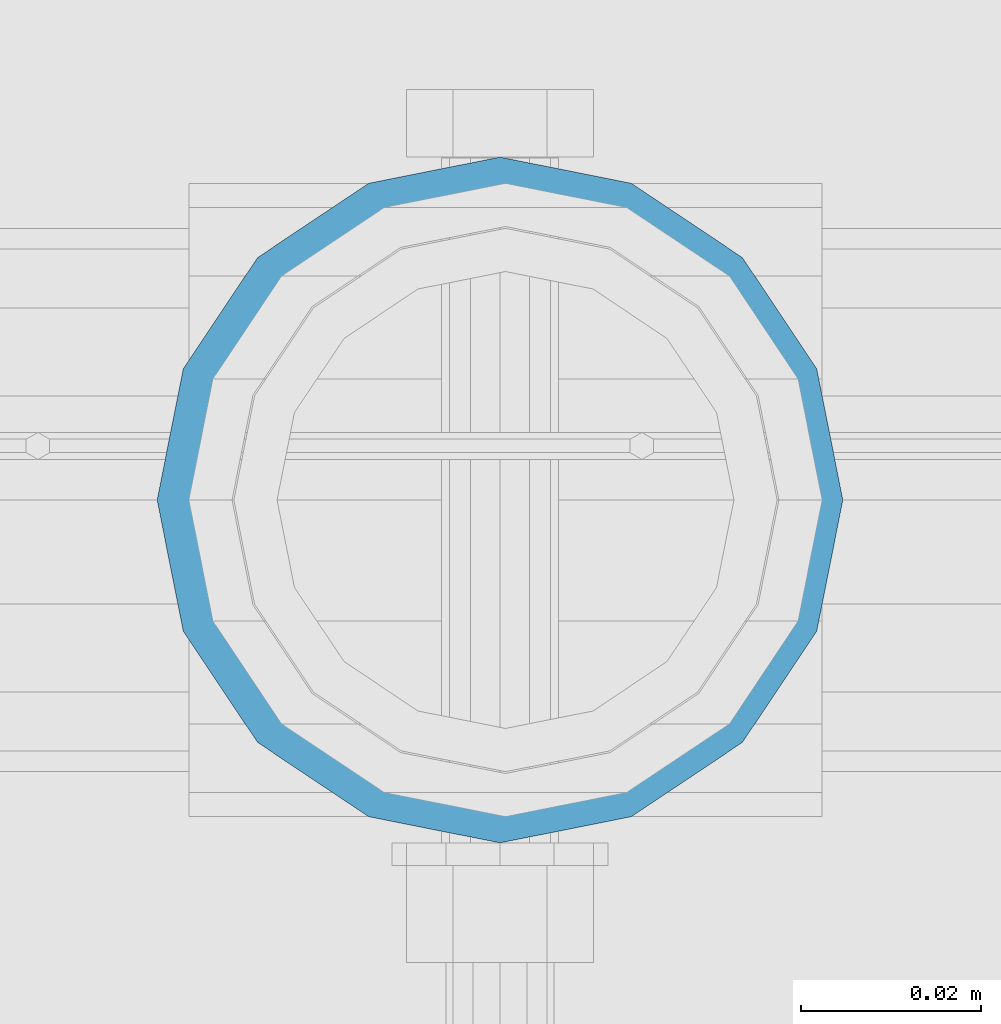
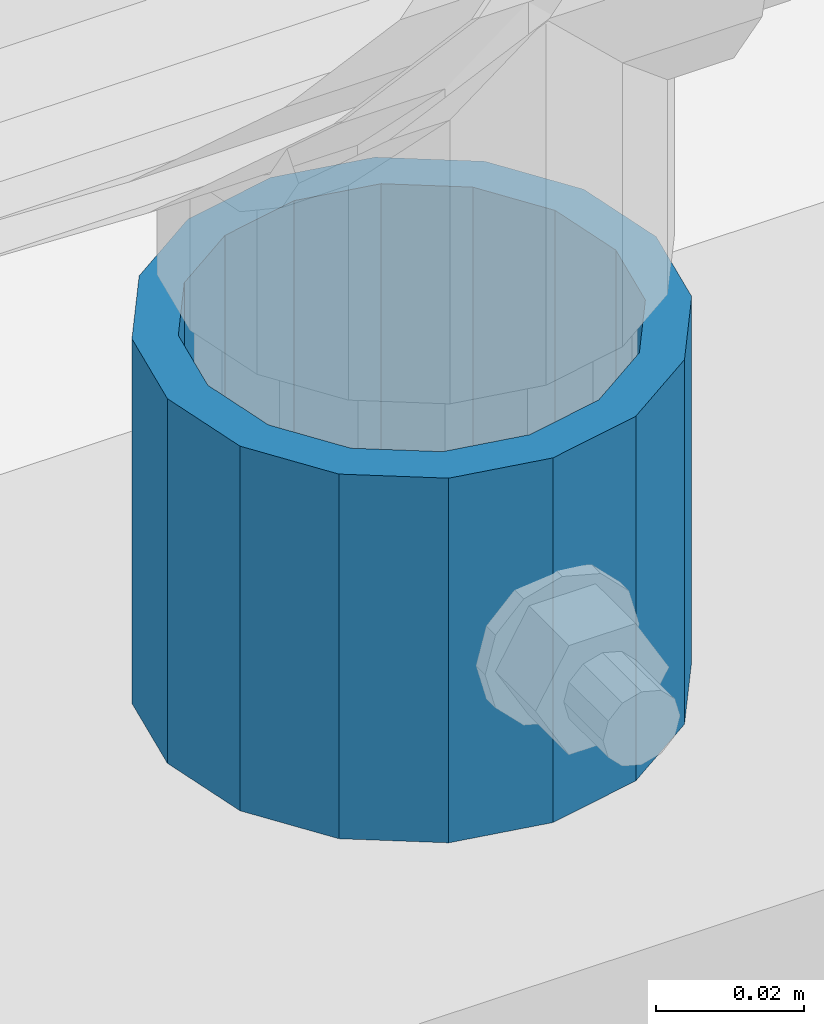
# One storey, part 96 of 240: 1 column.
"""IFC2X3 building model written with IfcOpenShell, lengths in millimetres."""

from ifc_helpers import new_model, si_unit, frame, origin_with_axes, place, context, subcontext, project, spatial, faceted_brep, material, type_object, element, save


model = new_model("IFC2X3")

# Units and contexts
model_context = context("Model", 3, precision=1e-05, world=origin_with_axes())
body_context = subcontext(model_context, "Body", "Model", "MODEL_VIEW")
ifc_project = project(units=[si_unit("LENGTHUNIT", "METRE", prefix="MILLI"), si_unit("AREAUNIT", "SQUARE_METRE"), si_unit("VOLUMEUNIT", "CUBIC_METRE"), si_unit("MASSUNIT", "GRAM", prefix="KILO"), si_unit("TIMEUNIT", "SECOND"), si_unit("PLANEANGLEUNIT", "RADIAN"), si_unit("SOLIDANGLEUNIT", "STERADIAN"), si_unit("THERMODYNAMICTEMPERATUREUNIT", "DEGREE_CELSIUS"), si_unit("LUMINOUSINTENSITYUNIT", "LUMEN")], contexts=[model_context])

# Site, building, storey
site_placement = place(None, origin_with_axes())
site = spatial("IfcSite", under=ifc_project, at=site_placement, CompositionType="ELEMENT")
building_placement = place(site_placement, origin_with_axes())
building = spatial("IfcBuilding", under=site, at=building_placement, Name="Standard", CompositionType="ELEMENT")
storey_placement = place(building_placement, origin_with_axes())
storey = spatial("IfcBuildingStorey", under=building, at=storey_placement, Name="Undefined", CompositionType="ELEMENT", Elevation=0.0)

# Column
ifc_material = material()
column_type = type_object("IfcColumnType", PredefinedType="NOTDEFINED")
column_placement = place(storey_placement, frame((55181.0, 34664.5, 168.019999999998), z_axis=(0.0, 1.0, 0.0), x_axis=(0.0, 0.0, 1.0)))
element("IfcColumn", 1, at=column_placement, inside=storey, type_object=column_type, material=ifc_material, context=body_context, shape_type="Brep", body=[
    faceted_brep([(0.0, -31.75, 0.0), (0.0, -29.3331751572332, 12.1501989775934), (60.0, -29.3331751572332, 12.1501989775934), (60.0, -31.75, 0.0), (0.0, -22.4506403026753, 22.4506403026753), (60.0, -22.4506403026753, 22.4506403026753), (0.0, -12.1501989775934, 29.3331751572332), (60.0, -12.1501989775934, 29.3331751572332), (0.0, 0.0, 31.75), (60.0, 0.0, 31.75), (0.0, 12.1501989775934, 29.3331751572332), (60.0, 12.1501989775934, 29.3331751572332), (0.0, 22.4506403026753, 22.4506403026753), (60.0, 22.4506403026753, 22.4506403026753), (0.0, 29.3331751572332, 12.1501989775934), (60.0, 29.3331751572332, 12.1501989775934), (0.0, 31.75, 0.0), (60.0, 31.75, 0.0), (0.0, 29.3331751572332, -12.1501989775934), (60.0, 29.3331751572332, -12.1501989775934), (0.0, 22.4506403026753, -22.4506403026753), (60.0, 22.4506403026753, -22.4506403026753), (0.0, 12.1501989775934, -29.3331751572332), (60.0, 12.1501989775934, -29.3331751572332), (0.0, 0.0, -31.75), (60.0, 0.0, -31.75), (0.0, -12.1501989775934, -29.3331751572332), (60.0, -12.1501989775934, -29.3331751572332), (0.0, -22.4506403026753, -22.4506403026753), (60.0, -22.4506403026753, -22.4506403026753), (0.0, -29.3331751572332, -12.1501989775934), (60.0, -29.3331751572332, -12.1501989775934), (0.0, -38.0500000000029, 0.0), (0.0, -35.1536162120537, -14.5611046014892), (60.0, -35.1536162120537, -14.5611046014892), (60.0, -38.0500000000029, 0.0), (0.0, -26.9054130241493, -26.9054130241493), (60.0, -26.9054130241493, -26.9054130241493), (0.0, -14.5611046014892, -35.1536162120537), (60.0, -14.5611046014892, -35.1536162120537), (0.0, 0.0, -38.0500000000029), (60.0, 0.0, -38.0500000000029), (0.0, 14.5611046014892, -35.1536162120537), (60.0, 14.5611046014892, -35.1536162120537), (0.0, 26.9054130241493, -26.9054130241493), (60.0, 26.9054130241493, -26.9054130241493), (0.0, 35.1536162120537, -14.5611046014892), (60.0, 35.1536162120537, -14.5611046014892), (0.0, 38.0500000000029, 0.0), (60.0, 38.0500000000029, 0.0), (0.0, 35.1536162120537, 14.5611046014892), (60.0, 35.1536162120537, 14.5611046014892), (0.0, 26.9054130241493, 26.9054130241493), (60.0, 26.9054130241493, 26.9054130241493), (0.0, 14.5611046014892, 35.1536162120537), (60.0, 14.5611046014892, 35.1536162120537), (0.0, 0.0, 38.0500000000029), (60.0, 0.0, 38.0500000000029), (0.0, -14.5611046014892, 35.1536162120537), (60.0, -14.5611046014892, 35.1536162120537), (0.0, -26.9054130241493, 26.9054130241493), (60.0, -26.9054130241493, 26.9054130241493), (0.0, -35.1536162120537, 14.5611046014892), (60.0, -35.1536162120537, 14.5611046014892)], [[[0, 1, 2, 3]], [[1, 4, 5, 2]], [[4, 6, 7, 5]], [[6, 8, 9, 7]], [[8, 10, 11, 9]], [[10, 12, 13, 11]], [[12, 14, 15, 13]], [[14, 16, 17, 15]], [[16, 18, 19, 17]], [[18, 20, 21, 19]], [[20, 22, 23, 21]], [[22, 24, 25, 23]], [[24, 26, 27, 25]], [[26, 28, 29, 27]], [[28, 30, 31, 29]], [[30, 0, 3, 31]], [[32, 33, 34, 35]], [[33, 36, 37, 34]], [[36, 38, 39, 37]], [[38, 40, 41, 39]], [[40, 42, 43, 41]], [[42, 44, 45, 43]], [[44, 46, 47, 45]], [[46, 48, 49, 47]], [[48, 50, 51, 49]], [[50, 52, 53, 51]], [[52, 54, 55, 53]], [[54, 56, 57, 55]], [[56, 58, 59, 57]], [[58, 60, 61, 59]], [[60, 62, 63, 61]], [[62, 32, 35, 63]], [[37, 39, 41, 43, 45, 47, 49, 51, 53, 55, 57, 59, 61, 63, 35, 34], [5, 7, 9, 11, 13, 15, 17, 19, 21, 23, 25, 27, 29, 31, 3, 2]], [[62, 60, 58, 56, 54, 52, 50, 48, 46, 44, 42, 40, 38, 36, 33, 32], [30, 28, 26, 24, 22, 20, 18, 16, 14, 12, 10, 8, 6, 4, 1, 0]]]),
])

save(model, "model.ifc")
